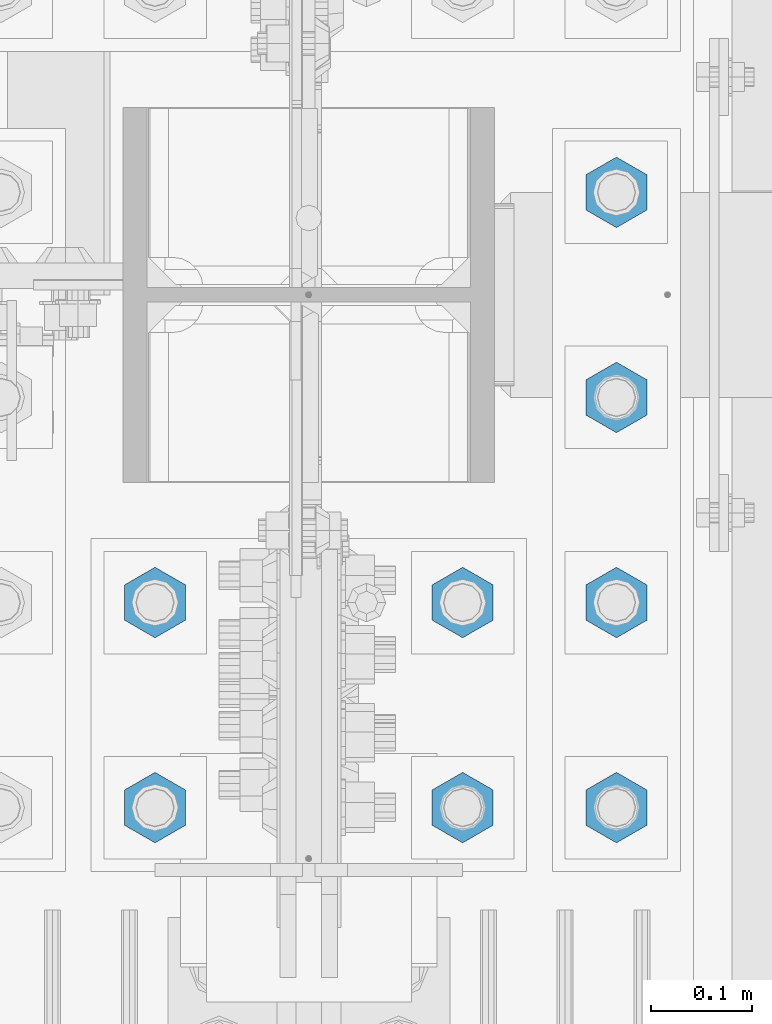
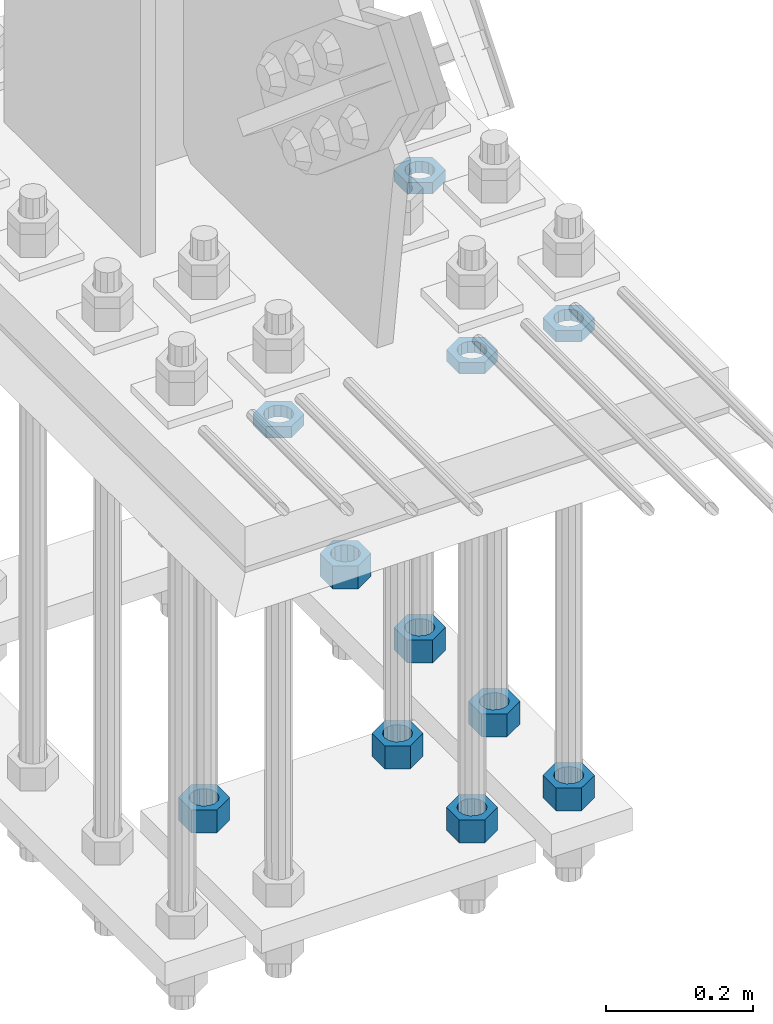
# One storey, part 2945 of 3843: 11 beams, 1 element without a shape of its own.
"""IFC2X3 building model written with IfcOpenShell, lengths in millimetres."""

from ifc_helpers import new_model, si_unit, frame, origin_with_axes, place, context, subcontext, project, spatial, faceted_brep, material, type_object, element, aggregate, save


model = new_model("IFC2X3")

# Units and contexts
model_context = context("Model", 3, precision=1e-05, world=origin_with_axes())
body_context = subcontext(model_context, "Body", "Model", "MODEL_VIEW")
ifc_project = project(units=[si_unit("LENGTHUNIT", "METRE", prefix="MILLI"), si_unit("AREAUNIT", "SQUARE_METRE"), si_unit("VOLUMEUNIT", "CUBIC_METRE"), si_unit("MASSUNIT", "GRAM", prefix="KILO"), si_unit("TIMEUNIT", "SECOND"), si_unit("PLANEANGLEUNIT", "RADIAN"), si_unit("SOLIDANGLEUNIT", "STERADIAN"), si_unit("THERMODYNAMICTEMPERATUREUNIT", "DEGREE_CELSIUS"), si_unit("LUMINOUSINTENSITYUNIT", "LUMEN")], contexts=[model_context])

# Site, building, storey
site_placement = place(None, origin_with_axes())
site = spatial("IfcSite", under=ifc_project, at=site_placement, CompositionType="ELEMENT")
building_placement = place(site_placement, origin_with_axes())
building = spatial("IfcBuilding", under=site, at=building_placement, Name="Undefined", CompositionType="ELEMENT")
storey_placement = place(building_placement, origin_with_axes())
storey = spatial("IfcBuildingStorey", under=building, at=storey_placement, Name="Undefined", CompositionType="ELEMENT", Elevation=0.0)

# Assembly, beams
assembly_placement = place(storey_placement, origin_with_axes())
assembly = element("IfcElementAssembly", 1, at=assembly_placement, inside=storey, Name="TEMPLATE", AssemblyPlace="NOTDEFINED", PredefinedType="RIGID_FRAME")
ifc_material = material(Name="STEEL/A572-50")
beam_type_1 = type_object("IfcBeamType", Name="1-1/2_HEAVY_HEX_NUT", PredefinedType="NOTDEFINED")
beam_1_placement = place(assembly_placement, frame((85496.4, 25311.1, 29298.9000015259), z_axis=(-1.0, 0.0, 0.0), x_axis=(0.0, 0.0, -1.0)))
beam_1 = element("IfcBeam", 2, at=beam_1_placement, type_object=beam_type_1, material=ifc_material, Name="NUT", ObjectType="1-1/2_HEAVY_HEX_NUT", context=body_context, shape_type="Brep", body=[
    faceted_brep([(0.0, -34.9199981689453, 0.0), (0.0, -17.4599990844727, -30.25), (38.0999999999985, -17.4599990844727, -30.25), (38.0999999999985, -34.9199981689453, 0.0), (0.0, 17.4599990844727, -30.25), (38.0999999999985, 17.4599990844727, -30.25), (0.0, 34.9199981689453, 0.0), (38.0999999999985, 34.9199981689453, 0.0), (0.0, 17.4599990844727, 30.25), (38.0999999999985, 17.4599990844727, 30.25), (0.0, -17.4599990844727, 30.25), (38.0999999999985, -17.4599990844727, 30.25), (0.0, 0.0, 20.6399993896484), (0.0, 8.9553601105581, 18.5959968835959), (38.0999999999985, 8.9553601105581, 18.5959968835959), (38.0999999999985, 0.0, 20.6399993896484), (0.0, 16.1370013209525, 12.8688291298167), (38.0999999999985, 16.1370013209525, 12.8688291298167), (0.0, 20.1225115123816, 4.59283194104501), (38.0999999999985, 20.1225115123816, 4.59283194104501), (0.0, 20.1225115123816, -4.59283194104501), (38.0999999999985, 20.1225115123816, -4.59283194104501), (0.0, 16.1370013209525, -12.8688291298167), (38.0999999999985, 16.1370013209525, -12.8688291298167), (0.0, 8.9553601105581, -18.5959968835959), (38.0999999999985, 8.9553601105581, -18.5959968835959), (0.0, 0.0, -20.6399993896484), (38.0999999999985, 0.0, -20.6399993896484), (0.0, -8.9553601105581, -18.5959968835959), (38.0999999999985, -8.9553601105581, -18.5959968835959), (0.0, -16.1370013209525, -12.8688291298167), (38.0999999999985, -16.1370013209525, -12.8688291298167), (0.0, -20.1225115123816, -4.59283194104501), (38.0999999999985, -20.1225115123816, -4.59283194104501), (0.0, -20.1225115123816, 4.59283194104501), (38.0999999999985, -20.1225115123816, 4.59283194104501), (0.0, -16.1370013209525, 12.8688291298167), (38.0999999999985, -16.1370013209525, 12.8688291298167), (0.0, -8.9553601105581, 18.5959968835959), (38.0999999999985, -8.9553601105581, 18.5959968835959)], [[[0, 1, 2, 3]], [[1, 4, 5, 2]], [[4, 6, 7, 5]], [[6, 8, 9, 7]], [[8, 10, 11, 9]], [[10, 0, 3, 11]], [[12, 13, 14, 15]], [[13, 16, 17, 14]], [[16, 18, 19, 17]], [[18, 20, 21, 19]], [[20, 22, 23, 21]], [[22, 24, 25, 23]], [[24, 26, 27, 25]], [[26, 28, 29, 27]], [[28, 30, 31, 29]], [[30, 32, 33, 31]], [[32, 34, 35, 33]], [[34, 36, 37, 35]], [[36, 38, 39, 37]], [[38, 12, 15, 39]], [[5, 7, 9, 11, 3, 2], [17, 19, 21, 23, 25, 27, 29, 31, 33, 35, 37, 39, 15, 14]], [[10, 8, 6, 4, 1, 0], [38, 36, 34, 32, 30, 28, 26, 24, 22, 20, 18, 16, 13, 12]]]),
])
beam_2_placement = place(assembly_placement, frame((85801.2, 25107.9, 29298.9000015259), z_axis=(-1.0, 0.0, 0.0), x_axis=(0.0, 0.0, -1.0)))
beam_2 = element("IfcBeam", 3, at=beam_2_placement, type_object=beam_type_1, material=ifc_material, Name="NUT", ObjectType="1-1/2_HEAVY_HEX_NUT", context=body_context, shape_type="Brep", body=[
    faceted_brep([(0.0, -34.9199981689453, 0.0), (0.0, -17.4599990844727, -30.25), (38.0999999999985, -17.4599990844727, -30.25), (38.0999999999985, -34.9199981689453, 0.0), (0.0, 17.4599990844727, -30.25), (38.0999999999985, 17.4599990844727, -30.25), (0.0, 34.9199981689453, 0.0), (38.0999999999985, 34.9199981689453, 0.0), (0.0, 17.4599990844727, 30.25), (38.0999999999985, 17.4599990844727, 30.25), (0.0, -17.4599990844727, 30.25), (38.0999999999985, -17.4599990844727, 30.25), (0.0, 0.0, 20.6399993896484), (0.0, 8.9553601105581, 18.5959968835959), (38.0999999999985, 8.9553601105581, 18.5959968835959), (38.0999999999985, 0.0, 20.6399993896484), (0.0, 16.1370013209525, 12.8688291298167), (38.0999999999985, 16.1370013209525, 12.8688291298167), (0.0, 20.1225115123816, 4.59283194104501), (38.0999999999985, 20.1225115123816, 4.59283194104501), (0.0, 20.1225115123816, -4.59283194104501), (38.0999999999985, 20.1225115123816, -4.59283194104501), (0.0, 16.1370013209525, -12.8688291298167), (38.0999999999985, 16.1370013209525, -12.8688291298167), (0.0, 8.9553601105581, -18.5959968835959), (38.0999999999985, 8.9553601105581, -18.5959968835959), (0.0, 0.0, -20.6399993896484), (38.0999999999985, 0.0, -20.6399993896484), (0.0, -8.9553601105581, -18.5959968835959), (38.0999999999985, -8.9553601105581, -18.5959968835959), (0.0, -16.1370013209525, -12.8688291298167), (38.0999999999985, -16.1370013209525, -12.8688291298167), (0.0, -20.1225115123816, -4.59283194104501), (38.0999999999985, -20.1225115123816, -4.59283194104501), (0.0, -20.1225115123816, 4.59283194104501), (38.0999999999985, -20.1225115123816, 4.59283194104501), (0.0, -16.1370013209525, 12.8688291298167), (38.0999999999985, -16.1370013209525, 12.8688291298167), (0.0, -8.9553601105581, 18.5959968835959), (38.0999999999985, -8.9553601105581, 18.5959968835959)], [[[0, 1, 2, 3]], [[1, 4, 5, 2]], [[4, 6, 7, 5]], [[6, 8, 9, 7]], [[8, 10, 11, 9]], [[10, 0, 3, 11]], [[12, 13, 14, 15]], [[13, 16, 17, 14]], [[16, 18, 19, 17]], [[18, 20, 21, 19]], [[20, 22, 23, 21]], [[22, 24, 25, 23]], [[24, 26, 27, 25]], [[26, 28, 29, 27]], [[28, 30, 31, 29]], [[30, 32, 33, 31]], [[32, 34, 35, 33]], [[34, 36, 37, 35]], [[36, 38, 39, 37]], [[38, 12, 15, 39]], [[5, 7, 9, 11, 3, 2], [17, 19, 21, 23, 25, 27, 29, 31, 33, 35, 37, 39, 15, 14]], [[10, 8, 6, 4, 1, 0], [38, 36, 34, 32, 30, 28, 26, 24, 22, 20, 18, 16, 13, 12]]]),
])
beam_3_placement = place(assembly_placement, frame((85801.2, 25311.1, 29298.9000015259), z_axis=(-1.0, 0.0, 0.0), x_axis=(0.0, 0.0, -1.0)))
beam_3 = element("IfcBeam", 4, at=beam_3_placement, type_object=beam_type_1, material=ifc_material, Name="NUT", ObjectType="1-1/2_HEAVY_HEX_NUT", context=body_context, shape_type="Brep", body=[
    faceted_brep([(0.0, -34.9199981689453, 0.0), (0.0, -17.4599990844727, -30.25), (38.0999999999985, -17.4599990844727, -30.25), (38.0999999999985, -34.9199981689453, 0.0), (0.0, 17.4599990844727, -30.25), (38.0999999999985, 17.4599990844727, -30.25), (0.0, 34.9199981689453, 0.0), (38.0999999999985, 34.9199981689453, 0.0), (0.0, 17.4599990844727, 30.25), (38.0999999999985, 17.4599990844727, 30.25), (0.0, -17.4599990844727, 30.25), (38.0999999999985, -17.4599990844727, 30.25), (0.0, 0.0, 20.6399993896484), (0.0, 8.9553601105581, 18.5959968835959), (38.0999999999985, 8.9553601105581, 18.5959968835959), (38.0999999999985, 0.0, 20.6399993896484), (0.0, 16.1370013209525, 12.8688291298167), (38.0999999999985, 16.1370013209525, 12.8688291298167), (0.0, 20.1225115123816, 4.59283194104501), (38.0999999999985, 20.1225115123816, 4.59283194104501), (0.0, 20.1225115123816, -4.59283194104501), (38.0999999999985, 20.1225115123816, -4.59283194104501), (0.0, 16.1370013209525, -12.8688291298167), (38.0999999999985, 16.1370013209525, -12.8688291298167), (0.0, 8.9553601105581, -18.5959968835959), (38.0999999999985, 8.9553601105581, -18.5959968835959), (0.0, 0.0, -20.6399993896484), (38.0999999999985, 0.0, -20.6399993896484), (0.0, -8.9553601105581, -18.5959968835959), (38.0999999999985, -8.9553601105581, -18.5959968835959), (0.0, -16.1370013209525, -12.8688291298167), (38.0999999999985, -16.1370013209525, -12.8688291298167), (0.0, -20.1225115123816, -4.59283194104501), (38.0999999999985, -20.1225115123816, -4.59283194104501), (0.0, -20.1225115123816, 4.59283194104501), (38.0999999999985, -20.1225115123816, 4.59283194104501), (0.0, -16.1370013209525, 12.8688291298167), (38.0999999999985, -16.1370013209525, 12.8688291298167), (0.0, -8.9553601105581, 18.5959968835959), (38.0999999999985, -8.9553601105581, 18.5959968835959)], [[[0, 1, 2, 3]], [[1, 4, 5, 2]], [[4, 6, 7, 5]], [[6, 8, 9, 7]], [[8, 10, 11, 9]], [[10, 0, 3, 11]], [[12, 13, 14, 15]], [[13, 16, 17, 14]], [[16, 18, 19, 17]], [[18, 20, 21, 19]], [[20, 22, 23, 21]], [[22, 24, 25, 23]], [[24, 26, 27, 25]], [[26, 28, 29, 27]], [[28, 30, 31, 29]], [[30, 32, 33, 31]], [[32, 34, 35, 33]], [[34, 36, 37, 35]], [[36, 38, 39, 37]], [[38, 12, 15, 39]], [[5, 7, 9, 11, 3, 2], [17, 19, 21, 23, 25, 27, 29, 31, 33, 35, 37, 39, 15, 14]], [[10, 8, 6, 4, 1, 0], [38, 36, 34, 32, 30, 28, 26, 24, 22, 20, 18, 16, 13, 12]]]),
])
beam_4_placement = place(assembly_placement, frame((85953.6, 25717.5, 29298.9000015259), z_axis=(1.0, 0.0, 0.0), x_axis=(0.0, 0.0, -1.0)))
beam_4 = element("IfcBeam", 5, at=beam_4_placement, type_object=beam_type_1, material=ifc_material, Name="NUT", ObjectType="1-1/2_HEAVY_HEX_NUT", context=body_context, shape_type="Brep", body=[
    faceted_brep([(0.0, -34.9199981689453, 0.0), (0.0, -17.4599990844727, -30.25), (38.0999999999985, -17.4599990844727, -30.25), (38.0999999999985, -34.9199981689453, 0.0), (0.0, 17.4599990844727, -30.25), (38.0999999999985, 17.4599990844727, -30.25), (0.0, 34.9199981689453, 0.0), (38.0999999999985, 34.9199981689453, 0.0), (0.0, 17.4599990844727, 30.25), (38.0999999999985, 17.4599990844727, 30.25), (0.0, -17.4599990844727, 30.25), (38.0999999999985, -17.4599990844727, 30.25), (0.0, 0.0, 20.6399993896484), (0.0, 8.9553601105581, 18.5959968835959), (38.0999999999985, 8.9553601105581, 18.5959968835959), (38.0999999999985, 0.0, 20.6399993896484), (0.0, 16.1370013209525, 12.8688291298167), (38.0999999999985, 16.1370013209525, 12.8688291298167), (0.0, 20.1225115123816, 4.59283194104501), (38.0999999999985, 20.1225115123816, 4.59283194104501), (0.0, 20.1225115123816, -4.59283194104501), (38.0999999999985, 20.1225115123816, -4.59283194104501), (0.0, 16.1370013209525, -12.8688291298167), (38.0999999999985, 16.1370013209525, -12.8688291298167), (0.0, 8.9553601105581, -18.5959968835959), (38.0999999999985, 8.9553601105581, -18.5959968835959), (0.0, 0.0, -20.6399993896484), (38.0999999999985, 0.0, -20.6399993896484), (0.0, -8.9553601105581, -18.5959968835959), (38.0999999999985, -8.9553601105581, -18.5959968835959), (0.0, -16.1370013209525, -12.8688291298167), (38.0999999999985, -16.1370013209525, -12.8688291298167), (0.0, -20.1225115123816, -4.59283194104501), (38.0999999999985, -20.1225115123816, -4.59283194104501), (0.0, -20.1225115123816, 4.59283194104501), (38.0999999999985, -20.1225115123816, 4.59283194104501), (0.0, -16.1370013209525, 12.8688291298167), (38.0999999999985, -16.1370013209525, 12.8688291298167), (0.0, -8.9553601105581, 18.5959968835959), (38.0999999999985, -8.9553601105581, 18.5959968835959)], [[[0, 1, 2, 3]], [[1, 4, 5, 2]], [[4, 6, 7, 5]], [[6, 8, 9, 7]], [[8, 10, 11, 9]], [[10, 0, 3, 11]], [[12, 13, 14, 15]], [[13, 16, 17, 14]], [[16, 18, 19, 17]], [[18, 20, 21, 19]], [[20, 22, 23, 21]], [[22, 24, 25, 23]], [[24, 26, 27, 25]], [[26, 28, 29, 27]], [[28, 30, 31, 29]], [[30, 32, 33, 31]], [[32, 34, 35, 33]], [[34, 36, 37, 35]], [[36, 38, 39, 37]], [[38, 12, 15, 39]], [[5, 7, 9, 11, 3, 2], [17, 19, 21, 23, 25, 27, 29, 31, 33, 35, 37, 39, 15, 14]], [[10, 8, 6, 4, 1, 0], [38, 36, 34, 32, 30, 28, 26, 24, 22, 20, 18, 16, 13, 12]]]),
])
beam_5_placement = place(assembly_placement, frame((85953.6, 25514.3, 29298.9000015259), z_axis=(1.0, 0.0, 0.0), x_axis=(0.0, 0.0, -1.0)))
beam_5 = element("IfcBeam", 6, at=beam_5_placement, type_object=beam_type_1, material=ifc_material, Name="NUT", ObjectType="1-1/2_HEAVY_HEX_NUT", context=body_context, shape_type="Brep", body=[
    faceted_brep([(0.0, -34.9199981689453, 0.0), (0.0, -17.4599990844727, -30.25), (38.0999999999985, -17.4599990844727, -30.25), (38.0999999999985, -34.9199981689453, 0.0), (0.0, 17.4599990844727, -30.25), (38.0999999999985, 17.4599990844727, -30.25), (0.0, 34.9199981689453, 0.0), (38.0999999999985, 34.9199981689453, 0.0), (0.0, 17.4599990844727, 30.25), (38.0999999999985, 17.4599990844727, 30.25), (0.0, -17.4599990844727, 30.25), (38.0999999999985, -17.4599990844727, 30.25), (0.0, 0.0, 20.6399993896484), (0.0, 8.9553601105581, 18.5959968835959), (38.0999999999985, 8.9553601105581, 18.5959968835959), (38.0999999999985, 0.0, 20.6399993896484), (0.0, 16.1370013209525, 12.8688291298167), (38.0999999999985, 16.1370013209525, 12.8688291298167), (0.0, 20.1225115123816, 4.59283194104501), (38.0999999999985, 20.1225115123816, 4.59283194104501), (0.0, 20.1225115123816, -4.59283194104501), (38.0999999999985, 20.1225115123816, -4.59283194104501), (0.0, 16.1370013209525, -12.8688291298167), (38.0999999999985, 16.1370013209525, -12.8688291298167), (0.0, 8.9553601105581, -18.5959968835959), (38.0999999999985, 8.9553601105581, -18.5959968835959), (0.0, 0.0, -20.6399993896484), (38.0999999999985, 0.0, -20.6399993896484), (0.0, -8.9553601105581, -18.5959968835959), (38.0999999999985, -8.9553601105581, -18.5959968835959), (0.0, -16.1370013209525, -12.8688291298167), (38.0999999999985, -16.1370013209525, -12.8688291298167), (0.0, -20.1225115123816, -4.59283194104501), (38.0999999999985, -20.1225115123816, -4.59283194104501), (0.0, -20.1225115123816, 4.59283194104501), (38.0999999999985, -20.1225115123816, 4.59283194104501), (0.0, -16.1370013209525, 12.8688291298167), (38.0999999999985, -16.1370013209525, 12.8688291298167), (0.0, -8.9553601105581, 18.5959968835959), (38.0999999999985, -8.9553601105581, 18.5959968835959)], [[[0, 1, 2, 3]], [[1, 4, 5, 2]], [[4, 6, 7, 5]], [[6, 8, 9, 7]], [[8, 10, 11, 9]], [[10, 0, 3, 11]], [[12, 13, 14, 15]], [[13, 16, 17, 14]], [[16, 18, 19, 17]], [[18, 20, 21, 19]], [[20, 22, 23, 21]], [[22, 24, 25, 23]], [[24, 26, 27, 25]], [[26, 28, 29, 27]], [[28, 30, 31, 29]], [[30, 32, 33, 31]], [[32, 34, 35, 33]], [[34, 36, 37, 35]], [[36, 38, 39, 37]], [[38, 12, 15, 39]], [[5, 7, 9, 11, 3, 2], [17, 19, 21, 23, 25, 27, 29, 31, 33, 35, 37, 39, 15, 14]], [[10, 8, 6, 4, 1, 0], [38, 36, 34, 32, 30, 28, 26, 24, 22, 20, 18, 16, 13, 12]]]),
])
beam_6_placement = place(assembly_placement, frame((85953.6, 25311.1, 29298.9000015259), z_axis=(-1.0, 0.0, 0.0), x_axis=(0.0, 0.0, -1.0)))
beam_6 = element("IfcBeam", 7, at=beam_6_placement, type_object=beam_type_1, material=ifc_material, Name="NUT", ObjectType="1-1/2_HEAVY_HEX_NUT", context=body_context, shape_type="Brep", body=[
    faceted_brep([(0.0, -34.9199981689453, 0.0), (0.0, -17.4599990844727, -30.25), (38.0999999999985, -17.4599990844727, -30.25), (38.0999999999985, -34.9199981689453, 0.0), (0.0, 17.4599990844727, -30.25), (38.0999999999985, 17.4599990844727, -30.25), (0.0, 34.9199981689453, 0.0), (38.0999999999985, 34.9199981689453, 0.0), (0.0, 17.4599990844727, 30.25), (38.0999999999985, 17.4599990844727, 30.25), (0.0, -17.4599990844727, 30.25), (38.0999999999985, -17.4599990844727, 30.25), (0.0, 0.0, 20.6399993896484), (0.0, 8.9553601105581, 18.5959968835959), (38.0999999999985, 8.9553601105581, 18.5959968835959), (38.0999999999985, 0.0, 20.6399993896484), (0.0, 16.1370013209525, 12.8688291298167), (38.0999999999985, 16.1370013209525, 12.8688291298167), (0.0, 20.1225115123816, 4.59283194104501), (38.0999999999985, 20.1225115123816, 4.59283194104501), (0.0, 20.1225115123816, -4.59283194104501), (38.0999999999985, 20.1225115123816, -4.59283194104501), (0.0, 16.1370013209525, -12.8688291298167), (38.0999999999985, 16.1370013209525, -12.8688291298167), (0.0, 8.9553601105581, -18.5959968835959), (38.0999999999985, 8.9553601105581, -18.5959968835959), (0.0, 0.0, -20.6399993896484), (38.0999999999985, 0.0, -20.6399993896484), (0.0, -8.9553601105581, -18.5959968835959), (38.0999999999985, -8.9553601105581, -18.5959968835959), (0.0, -16.1370013209525, -12.8688291298167), (38.0999999999985, -16.1370013209525, -12.8688291298167), (0.0, -20.1225115123816, -4.59283194104501), (38.0999999999985, -20.1225115123816, -4.59283194104501), (0.0, -20.1225115123816, 4.59283194104501), (38.0999999999985, -20.1225115123816, 4.59283194104501), (0.0, -16.1370013209525, 12.8688291298167), (38.0999999999985, -16.1370013209525, 12.8688291298167), (0.0, -8.9553601105581, 18.5959968835959), (38.0999999999985, -8.9553601105581, 18.5959968835959)], [[[0, 1, 2, 3]], [[1, 4, 5, 2]], [[4, 6, 7, 5]], [[6, 8, 9, 7]], [[8, 10, 11, 9]], [[10, 0, 3, 11]], [[12, 13, 14, 15]], [[13, 16, 17, 14]], [[16, 18, 19, 17]], [[18, 20, 21, 19]], [[20, 22, 23, 21]], [[22, 24, 25, 23]], [[24, 26, 27, 25]], [[26, 28, 29, 27]], [[28, 30, 31, 29]], [[30, 32, 33, 31]], [[32, 34, 35, 33]], [[34, 36, 37, 35]], [[36, 38, 39, 37]], [[38, 12, 15, 39]], [[5, 7, 9, 11, 3, 2], [17, 19, 21, 23, 25, 27, 29, 31, 33, 35, 37, 39, 15, 14]], [[10, 8, 6, 4, 1, 0], [38, 36, 34, 32, 30, 28, 26, 24, 22, 20, 18, 16, 13, 12]]]),
])
beam_7_placement = place(assembly_placement, frame((85953.6, 25107.9, 29298.9000015259), z_axis=(-1.0, 0.0, 0.0), x_axis=(0.0, 0.0, -1.0)))
beam_7 = element("IfcBeam", 8, at=beam_7_placement, type_object=beam_type_1, material=ifc_material, Name="NUT", ObjectType="1-1/2_HEAVY_HEX_NUT", context=body_context, shape_type="Brep", body=[
    faceted_brep([(0.0, -34.9199981689453, 0.0), (0.0, -17.4599990844727, -30.25), (38.0999999999985, -17.4599990844727, -30.25), (38.0999999999985, -34.9199981689453, 0.0), (0.0, 17.4599990844727, -30.25), (38.0999999999985, 17.4599990844727, -30.25), (0.0, 34.9199981689453, 0.0), (38.0999999999985, 34.9199981689453, 0.0), (0.0, 17.4599990844727, 30.25), (38.0999999999985, 17.4599990844727, 30.25), (0.0, -17.4599990844727, 30.25), (38.0999999999985, -17.4599990844727, 30.25), (0.0, 0.0, 20.6399993896484), (0.0, 8.9553601105581, 18.5959968835959), (38.0999999999985, 8.9553601105581, 18.5959968835959), (38.0999999999985, 0.0, 20.6399993896484), (0.0, 16.1370013209525, 12.8688291298167), (38.0999999999985, 16.1370013209525, 12.8688291298167), (0.0, 20.1225115123816, 4.59283194104501), (38.0999999999985, 20.1225115123816, 4.59283194104501), (0.0, 20.1225115123816, -4.59283194104501), (38.0999999999985, 20.1225115123816, -4.59283194104501), (0.0, 16.1370013209525, -12.8688291298167), (38.0999999999985, 16.1370013209525, -12.8688291298167), (0.0, 8.9553601105581, -18.5959968835959), (38.0999999999985, 8.9553601105581, -18.5959968835959), (0.0, 0.0, -20.6399993896484), (38.0999999999985, 0.0, -20.6399993896484), (0.0, -8.9553601105581, -18.5959968835959), (38.0999999999985, -8.9553601105581, -18.5959968835959), (0.0, -16.1370013209525, -12.8688291298167), (38.0999999999985, -16.1370013209525, -12.8688291298167), (0.0, -20.1225115123816, -4.59283194104501), (38.0999999999985, -20.1225115123816, -4.59283194104501), (0.0, -20.1225115123816, 4.59283194104501), (38.0999999999985, -20.1225115123816, 4.59283194104501), (0.0, -16.1370013209525, 12.8688291298167), (38.0999999999985, -16.1370013209525, 12.8688291298167), (0.0, -8.9553601105581, 18.5959968835959), (38.0999999999985, -8.9553601105581, 18.5959968835959)], [[[0, 1, 2, 3]], [[1, 4, 5, 2]], [[4, 6, 7, 5]], [[6, 8, 9, 7]], [[8, 10, 11, 9]], [[10, 0, 3, 11]], [[12, 13, 14, 15]], [[13, 16, 17, 14]], [[16, 18, 19, 17]], [[18, 20, 21, 19]], [[20, 22, 23, 21]], [[22, 24, 25, 23]], [[24, 26, 27, 25]], [[26, 28, 29, 27]], [[28, 30, 31, 29]], [[30, 32, 33, 31]], [[32, 34, 35, 33]], [[34, 36, 37, 35]], [[36, 38, 39, 37]], [[38, 12, 15, 39]], [[5, 7, 9, 11, 3, 2], [17, 19, 21, 23, 25, 27, 29, 31, 33, 35, 37, 39, 15, 14]], [[10, 8, 6, 4, 1, 0], [38, 36, 34, 32, 30, 28, 26, 24, 22, 20, 18, 16, 13, 12]]]),
])
beam_type_2 = type_object("IfcBeamType", Name="1-1/2_HALF_NUT", PredefinedType="NOTDEFINED")
beam_8_placement = place(assembly_placement, frame((85496.4, 25107.9, 30060.9), z_axis=(-1.0, 0.0, 0.0), x_axis=(0.0, 0.0, -1.0)))
beam_8 = element("IfcBeam", 9, at=beam_8_placement, type_object=beam_type_2, material=ifc_material, Name="NUT", ObjectType="1-1/2_HALF_NUT", context=body_context, shape_type="Brep", body=[
    faceted_brep([(0.0, -34.9199981689453, 0.0), (0.0, -17.4599990844727, -30.25), (19.0500000000029, -17.4599990844727, -30.25), (19.0500000000029, -34.9199981689453, 0.0), (0.0, 17.4599990844727, -30.25), (19.0500000000029, 17.4599990844727, -30.25), (0.0, 34.9199981689453, 0.0), (19.0500000000029, 34.9199981689453, 0.0), (0.0, 17.4599990844727, 30.25), (19.0500000000029, 17.4599990844727, 30.25), (0.0, -17.4599990844727, 30.25), (19.0500000000029, -17.4599990844727, 30.25), (0.0, 0.0, 20.6399993896484), (0.0, 8.9553601105581, 18.5959968835959), (19.0500000000029, 8.95536011056538, 18.5959968835959), (19.0500000000029, 0.0, 20.6399993896484), (0.0, 16.1370013209525, 12.8688291298167), (19.0500000000029, 16.1370013209489, 12.8688291298167), (0.0, 20.1225115123816, 4.59283194104501), (19.0500000000029, 20.1225115123852, 4.59283194104501), (0.0, 20.1225115123816, -4.59283194104501), (19.0500000000029, 20.1225115123852, -4.59283194104501), (0.0, 16.1370013209525, -12.8688291298167), (19.0500000000029, 16.1370013209489, -12.8688291298167), (0.0, 8.9553601105581, -18.5959968835959), (19.0500000000029, 8.95536011056538, -18.5959968835959), (0.0, 0.0, -20.6399993896484), (19.0500000000029, 0.0, -20.6399993896484), (0.0, -8.9553601105581, -18.5959968835959), (19.0500000000029, -8.95536011056538, -18.5959968835959), (0.0, -16.1370013209525, -12.8688291298167), (19.0500000000029, -16.1370013209489, -12.8688291298167), (0.0, -20.1225115123816, -4.59283194104501), (19.0500000000029, -20.1225115123852, -4.59283194104501), (0.0, -20.1225115123816, 4.59283194104501), (19.0500000000029, -20.1225115123852, 4.59283194104501), (0.0, -16.1370013209525, 12.8688291298167), (19.0500000000029, -16.1370013209489, 12.8688291298167), (0.0, -8.9553601105581, 18.5959968835959), (19.0500000000029, -8.95536011056538, 18.5959968835959)], [[[0, 1, 2, 3]], [[1, 4, 5, 2]], [[4, 6, 7, 5]], [[6, 8, 9, 7]], [[8, 10, 11, 9]], [[10, 0, 3, 11]], [[12, 13, 14, 15]], [[13, 16, 17, 14]], [[16, 18, 19, 17]], [[18, 20, 21, 19]], [[20, 22, 23, 21]], [[22, 24, 25, 23]], [[24, 26, 27, 25]], [[26, 28, 29, 27]], [[28, 30, 31, 29]], [[30, 32, 33, 31]], [[32, 34, 35, 33]], [[34, 36, 37, 35]], [[36, 38, 39, 37]], [[38, 12, 15, 39]], [[5, 7, 9, 11, 3, 2], [17, 19, 21, 23, 25, 27, 29, 31, 33, 35, 37, 39, 15, 14]], [[10, 8, 6, 4, 1, 0], [38, 36, 34, 32, 30, 28, 26, 24, 22, 20, 18, 16, 13, 12]]]),
])
beam_9_placement = place(assembly_placement, frame((85801.2, 25107.9, 30060.9), z_axis=(-1.0, 0.0, 0.0), x_axis=(0.0, 0.0, -1.0)))
beam_9 = element("IfcBeam", 10, at=beam_9_placement, type_object=beam_type_2, material=ifc_material, Name="NUT", ObjectType="1-1/2_HALF_NUT", context=body_context, shape_type="Brep", body=[
    faceted_brep([(0.0, -34.9199981689453, 0.0), (0.0, -17.4599990844727, -30.25), (19.0500000000029, -17.4599990844727, -30.25), (19.0500000000029, -34.9199981689453, 0.0), (0.0, 17.4599990844727, -30.25), (19.0500000000029, 17.4599990844727, -30.25), (0.0, 34.9199981689453, 0.0), (19.0500000000029, 34.9199981689453, 0.0), (0.0, 17.4599990844727, 30.25), (19.0500000000029, 17.4599990844727, 30.25), (0.0, -17.4599990844727, 30.25), (19.0500000000029, -17.4599990844727, 30.25), (0.0, 0.0, 20.6399993896484), (0.0, 8.9553601105581, 18.5959968835959), (19.0500000000029, 8.95536011056538, 18.5959968835959), (19.0500000000029, 0.0, 20.6399993896484), (0.0, 16.1370013209525, 12.8688291298167), (19.0500000000029, 16.1370013209489, 12.8688291298167), (0.0, 20.1225115123816, 4.59283194104501), (19.0500000000029, 20.1225115123852, 4.59283194104501), (0.0, 20.1225115123816, -4.59283194104501), (19.0500000000029, 20.1225115123852, -4.59283194104501), (0.0, 16.1370013209525, -12.8688291298167), (19.0500000000029, 16.1370013209489, -12.8688291298167), (0.0, 8.9553601105581, -18.5959968835959), (19.0500000000029, 8.95536011056538, -18.5959968835959), (0.0, 0.0, -20.6399993896484), (19.0500000000029, 0.0, -20.6399993896484), (0.0, -8.9553601105581, -18.5959968835959), (19.0500000000029, -8.95536011056538, -18.5959968835959), (0.0, -16.1370013209525, -12.8688291298167), (19.0500000000029, -16.1370013209489, -12.8688291298167), (0.0, -20.1225115123816, -4.59283194104501), (19.0500000000029, -20.1225115123852, -4.59283194104501), (0.0, -20.1225115123816, 4.59283194104501), (19.0500000000029, -20.1225115123852, 4.59283194104501), (0.0, -16.1370013209525, 12.8688291298167), (19.0500000000029, -16.1370013209489, 12.8688291298167), (0.0, -8.9553601105581, 18.5959968835959), (19.0500000000029, -8.95536011056538, 18.5959968835959)], [[[0, 1, 2, 3]], [[1, 4, 5, 2]], [[4, 6, 7, 5]], [[6, 8, 9, 7]], [[8, 10, 11, 9]], [[10, 0, 3, 11]], [[12, 13, 14, 15]], [[13, 16, 17, 14]], [[16, 18, 19, 17]], [[18, 20, 21, 19]], [[20, 22, 23, 21]], [[22, 24, 25, 23]], [[24, 26, 27, 25]], [[26, 28, 29, 27]], [[28, 30, 31, 29]], [[30, 32, 33, 31]], [[32, 34, 35, 33]], [[34, 36, 37, 35]], [[36, 38, 39, 37]], [[38, 12, 15, 39]], [[5, 7, 9, 11, 3, 2], [17, 19, 21, 23, 25, 27, 29, 31, 33, 35, 37, 39, 15, 14]], [[10, 8, 6, 4, 1, 0], [38, 36, 34, 32, 30, 28, 26, 24, 22, 20, 18, 16, 13, 12]]]),
])
beam_10_placement = place(assembly_placement, frame((85953.6, 25107.9, 30060.9), z_axis=(-1.0, 0.0, 0.0), x_axis=(0.0, 0.0, -1.0)))
beam_10 = element("IfcBeam", 11, at=beam_10_placement, type_object=beam_type_2, material=ifc_material, Name="NUT", ObjectType="1-1/2_HALF_NUT", context=body_context, shape_type="Brep", body=[
    faceted_brep([(0.0, -34.9199981689453, 0.0), (0.0, -17.4599990844727, -30.25), (19.0500000000029, -17.4599990844727, -30.25), (19.0500000000029, -34.9199981689453, 0.0), (0.0, 17.4599990844727, -30.25), (19.0500000000029, 17.4599990844727, -30.25), (0.0, 34.9199981689453, 0.0), (19.0500000000029, 34.9199981689453, 0.0), (0.0, 17.4599990844727, 30.25), (19.0500000000029, 17.4599990844727, 30.25), (0.0, -17.4599990844727, 30.25), (19.0500000000029, -17.4599990844727, 30.25), (0.0, 0.0, 20.6399993896484), (0.0, 8.9553601105581, 18.5959968835959), (19.0500000000029, 8.95536011056538, 18.5959968835959), (19.0500000000029, 0.0, 20.6399993896484), (0.0, 16.1370013209525, 12.8688291298167), (19.0500000000029, 16.1370013209489, 12.8688291298167), (0.0, 20.1225115123816, 4.59283194104501), (19.0500000000029, 20.1225115123852, 4.59283194104501), (0.0, 20.1225115123816, -4.59283194104501), (19.0500000000029, 20.1225115123852, -4.59283194104501), (0.0, 16.1370013209525, -12.8688291298167), (19.0500000000029, 16.1370013209489, -12.8688291298167), (0.0, 8.9553601105581, -18.5959968835959), (19.0500000000029, 8.95536011056538, -18.5959968835959), (0.0, 0.0, -20.6399993896484), (19.0500000000029, 0.0, -20.6399993896484), (0.0, -8.9553601105581, -18.5959968835959), (19.0500000000029, -8.95536011056538, -18.5959968835959), (0.0, -16.1370013209525, -12.8688291298167), (19.0500000000029, -16.1370013209489, -12.8688291298167), (0.0, -20.1225115123816, -4.59283194104501), (19.0500000000029, -20.1225115123852, -4.59283194104501), (0.0, -20.1225115123816, 4.59283194104501), (19.0500000000029, -20.1225115123852, 4.59283194104501), (0.0, -16.1370013209525, 12.8688291298167), (19.0500000000029, -16.1370013209489, 12.8688291298167), (0.0, -8.9553601105581, 18.5959968835959), (19.0500000000029, -8.95536011056538, 18.5959968835959)], [[[0, 1, 2, 3]], [[1, 4, 5, 2]], [[4, 6, 7, 5]], [[6, 8, 9, 7]], [[8, 10, 11, 9]], [[10, 0, 3, 11]], [[12, 13, 14, 15]], [[13, 16, 17, 14]], [[16, 18, 19, 17]], [[18, 20, 21, 19]], [[20, 22, 23, 21]], [[22, 24, 25, 23]], [[24, 26, 27, 25]], [[26, 28, 29, 27]], [[28, 30, 31, 29]], [[30, 32, 33, 31]], [[32, 34, 35, 33]], [[34, 36, 37, 35]], [[36, 38, 39, 37]], [[38, 12, 15, 39]], [[5, 7, 9, 11, 3, 2], [17, 19, 21, 23, 25, 27, 29, 31, 33, 35, 37, 39, 15, 14]], [[10, 8, 6, 4, 1, 0], [38, 36, 34, 32, 30, 28, 26, 24, 22, 20, 18, 16, 13, 12]]]),
])
beam_11_placement = place(assembly_placement, frame((85953.6, 25514.3, 30060.9), z_axis=(-1.0, 0.0, 0.0), x_axis=(0.0, 0.0, -1.0)))
beam_11 = element("IfcBeam", 12, at=beam_11_placement, type_object=beam_type_2, material=ifc_material, Name="NUT", ObjectType="1-1/2_HALF_NUT", context=body_context, shape_type="Brep", body=[
    faceted_brep([(0.0, -34.9199981689453, 0.0), (0.0, -17.4599990844727, -30.25), (19.0500000000029, -17.4599990844727, -30.25), (19.0500000000029, -34.9199981689453, 0.0), (0.0, 17.4599990844727, -30.25), (19.0500000000029, 17.4599990844727, -30.25), (0.0, 34.9199981689453, 0.0), (19.0500000000029, 34.9199981689453, 0.0), (0.0, 17.4599990844727, 30.25), (19.0500000000029, 17.4599990844727, 30.25), (0.0, -17.4599990844727, 30.25), (19.0500000000029, -17.4599990844727, 30.25), (0.0, 0.0, 20.6399993896484), (0.0, 8.9553601105581, 18.5959968835959), (19.0500000000029, 8.95536011056538, 18.5959968835959), (19.0500000000029, 0.0, 20.6399993896484), (0.0, 16.1370013209525, 12.8688291298167), (19.0500000000029, 16.1370013209489, 12.8688291298167), (0.0, 20.1225115123816, 4.59283194104501), (19.0500000000029, 20.1225115123852, 4.59283194104501), (0.0, 20.1225115123816, -4.59283194104501), (19.0500000000029, 20.1225115123852, -4.59283194104501), (0.0, 16.1370013209525, -12.8688291298167), (19.0500000000029, 16.1370013209489, -12.8688291298167), (0.0, 8.9553601105581, -18.5959968835959), (19.0500000000029, 8.95536011056538, -18.5959968835959), (0.0, 0.0, -20.6399993896484), (19.0500000000029, 0.0, -20.6399993896484), (0.0, -8.9553601105581, -18.5959968835959), (19.0500000000029, -8.95536011056538, -18.5959968835959), (0.0, -16.1370013209525, -12.8688291298167), (19.0500000000029, -16.1370013209489, -12.8688291298167), (0.0, -20.1225115123816, -4.59283194104501), (19.0500000000029, -20.1225115123852, -4.59283194104501), (0.0, -20.1225115123816, 4.59283194104501), (19.0500000000029, -20.1225115123852, 4.59283194104501), (0.0, -16.1370013209525, 12.8688291298167), (19.0500000000029, -16.1370013209489, 12.8688291298167), (0.0, -8.9553601105581, 18.5959968835959), (19.0500000000029, -8.95536011056538, 18.5959968835959)], [[[0, 1, 2, 3]], [[1, 4, 5, 2]], [[4, 6, 7, 5]], [[6, 8, 9, 7]], [[8, 10, 11, 9]], [[10, 0, 3, 11]], [[12, 13, 14, 15]], [[13, 16, 17, 14]], [[16, 18, 19, 17]], [[18, 20, 21, 19]], [[20, 22, 23, 21]], [[22, 24, 25, 23]], [[24, 26, 27, 25]], [[26, 28, 29, 27]], [[28, 30, 31, 29]], [[30, 32, 33, 31]], [[32, 34, 35, 33]], [[34, 36, 37, 35]], [[36, 38, 39, 37]], [[38, 12, 15, 39]], [[5, 7, 9, 11, 3, 2], [17, 19, 21, 23, 25, 27, 29, 31, 33, 35, 37, 39, 15, 14]], [[10, 8, 6, 4, 1, 0], [38, 36, 34, 32, 30, 28, 26, 24, 22, 20, 18, 16, 13, 12]]]),
])
aggregate(assembly, [beam_1, beam_2, beam_3, beam_4, beam_5, beam_6, beam_7, beam_8, beam_9, beam_10, beam_11])

save(model, "model.ifc")
